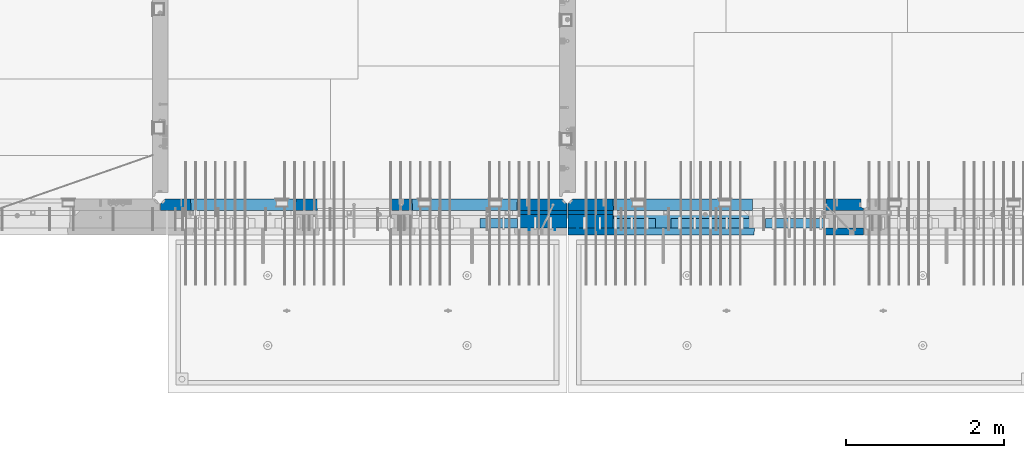
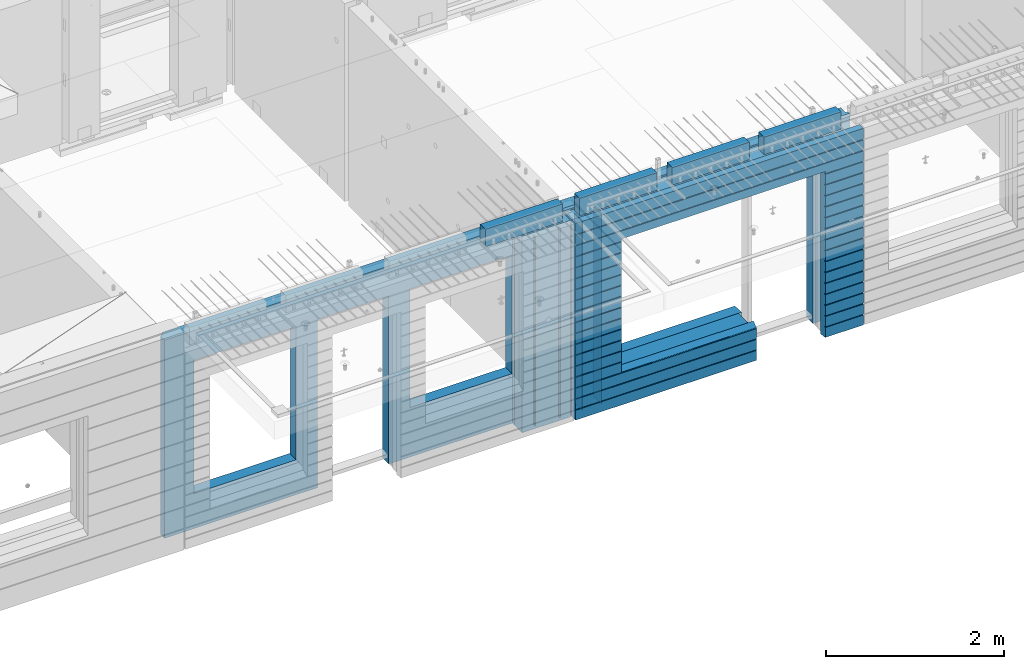
# One storey, part 232 of 352: 16 walls, 8 elements without a shape of their own.
"""IFC2X3 building model written with IfcOpenShell, lengths in millimetres."""

from ifc_helpers import new_model, si_unit, frame, origin_with_axes, place, context, subcontext, project, spatial, faceted_brep, material, type_object, element, aggregate, save


model = new_model("IFC2X3")

# Units and contexts
model_context = context("Model", 3, precision=1e-05, world=origin_with_axes())
body_context = subcontext(model_context, "Body", "Model", "MODEL_VIEW")
ifc_project = project(units=[si_unit("LENGTHUNIT", "METRE", prefix="MILLI"), si_unit("AREAUNIT", "SQUARE_METRE"), si_unit("VOLUMEUNIT", "CUBIC_METRE"), si_unit("MASSUNIT", "GRAM", prefix="KILO"), si_unit("TIMEUNIT", "SECOND"), si_unit("PLANEANGLEUNIT", "RADIAN"), si_unit("SOLIDANGLEUNIT", "STERADIAN"), si_unit("THERMODYNAMICTEMPERATUREUNIT", "DEGREE_CELSIUS"), si_unit("LUMINOUSINTENSITYUNIT", "LUMEN")], contexts=[model_context])

# Site, building, storey
site_placement = place(None, origin_with_axes())
site = spatial("IfcSite", under=ifc_project, at=site_placement, CompositionType="ELEMENT")
building_placement = place(site_placement, origin_with_axes())
building = spatial("IfcBuilding", under=site, at=building_placement, CompositionType="ELEMENT")
storey_placement = place(building_placement, origin_with_axes())
storey = spatial("IfcBuildingStorey", under=building, at=storey_placement, Name="6", CompositionType="ELEMENT", Elevation=0.0)

# Assembly, walls
assembly_1_placement = place(storey_placement, origin_with_axes())
assembly_1 = element("IfcElementAssembly", 1, at=assembly_1_placement, inside=storey, AssemblyPlace="NOTDEFINED", PredefinedType="REINFORCEMENT_UNIT")
ifc_material_1 = material(Name="Undefined")
wall_type_1 = type_object("IfcWallType", PredefinedType="NOTDEFINED")
wall_1_placement = place(assembly_1_placement, frame((21325.0, 7780.0, 98115.0), z_axis=(0.0, 0.0, 1.0), x_axis=(0.0, -1.0, 0.0)))
wall_1 = element("IfcWall", 2, at=wall_1_placement, type_object=wall_type_1, material=ifc_material_1, Name="(PD)", context=body_context, shape_type="Brep", body=[
    faceted_brep([(0.0, 5.0, -1300.0), (0.0, 5.0, 1300.0), (180.0, 5.0, 1300.0), (180.0, 5.0, -1300.0), (0.0, -5.0, 1300.0), (180.0, -5.0, 1300.0), (0.0, -5.0, -1300.0), (180.0, -5.0, -1300.0)], [[[0, 1, 2, 3]], [[1, 4, 5, 2]], [[4, 6, 7, 5]], [[6, 0, 3, 7]], [[5, 7, 3, 2]], [[6, 4, 1, 0]]]),
])
wall_2_placement = place(assembly_1_placement, frame((21650.0, 7780.0, 98115.0), z_axis=(0.0, 0.0, 1.0), x_axis=(0.0, -1.0, 0.0)))
wall_2 = element("IfcWall", 3, at=wall_2_placement, type_object=wall_type_1, material=ifc_material_1, Name="(PD)", context=body_context, shape_type="Brep", body=[
    faceted_brep([(0.0, 5.0, -1300.0), (0.0, 5.0, 1300.0), (180.0, 5.0, 1300.0), (180.0, 5.0, -1300.0), (0.0, -5.0, 1300.0), (180.0, -5.0, 1300.0), (0.0, -5.0, -1300.0), (180.0, -5.0, -1300.0)], [[[0, 1, 2, 3]], [[1, 4, 5, 2]], [[4, 6, 7, 5]], [[6, 0, 3, 7]], [[5, 7, 3, 2]], [[6, 4, 1, 0]]]),
])

assembly_2_placement = place(storey_placement, origin_with_axes())
assembly_2 = element("IfcElementAssembly", 4, at=assembly_2_placement, inside=storey, AssemblyPlace="NOTDEFINED", PredefinedType="REINFORCEMENT_UNIT")
wall_3_placement = place(assembly_2_placement, frame((22190.0, 7780.0, 98115.0), z_axis=(0.0, 0.0, 1.0), x_axis=(0.0, -1.0, 0.0)))
wall_3 = element("IfcWall", 5, at=wall_3_placement, type_object=wall_type_1, material=ifc_material_1, Name="(PD)", context=body_context, shape_type="Brep", body=[
    faceted_brep([(0.0, 5.0, -1300.0), (0.0, 5.0, 1300.0), (180.0, 5.0, 1300.0), (180.0, 5.0, -1300.0), (0.0, -5.0, 1300.0), (180.0, -5.0, 1300.0), (0.0, -5.0, -1300.0), (180.0, -5.0, -1300.0)], [[[0, 1, 2, 3]], [[1, 4, 5, 2]], [[4, 6, 7, 5]], [[6, 0, 3, 7]], [[5, 7, 3, 2]], [[6, 4, 1, 0]]]),
])
wall_4_placement = place(assembly_2_placement, frame((21940.0, 7780.0, 98115.0), z_axis=(0.0, 0.0, 1.0), x_axis=(0.0, -1.0, 0.0)))
wall_4 = element("IfcWall", 6, at=wall_4_placement, type_object=wall_type_1, material=ifc_material_1, Name="(PD)", context=body_context, shape_type="Brep", body=[
    faceted_brep([(0.0, 5.0, -1300.0), (0.0, 5.0, 1300.0), (180.0, 5.0, 1300.0), (180.0, 5.0, -1300.0), (0.0, -5.0, 1300.0), (180.0, -5.0, 1300.0), (0.0, -5.0, -1300.0), (180.0, -5.0, -1300.0)], [[[0, 1, 2, 3]], [[1, 4, 5, 2]], [[4, 6, 7, 5]], [[6, 0, 3, 7]], [[5, 7, 3, 2]], [[6, 4, 1, 0]]]),
])

# Assemblies, wall
assembly_3_placement = place(storey_placement, origin_with_axes())
assembly_3 = element("IfcElementAssembly", 7, at=assembly_3_placement, inside=storey, AssemblyPlace="NOTDEFINED", PredefinedType="REINFORCEMENT_UNIT")
assembly_4_placement = place(assembly_3_placement, origin_with_axes())
assembly_4 = element("IfcElementAssembly", 8, at=assembly_4_placement, Name="Steel Assembly", AssemblyPlace="NOTDEFINED", PredefinedType="NOTDEFINED")
aggregate(assembly_3, [assembly_4])
ifc_material_2 = material()
wall_type_2 = type_object("IfcWallType", PredefinedType="NOTDEFINED")
wall_5_placement = place(assembly_4_placement, frame((20699.9998568133, 7690.00021946163, 99590.0), z_axis=(0.0, 0.0, 1.0), x_axis=(1.0, 0.0, 0.0)))
wall_5 = element("IfcWall", 9, at=wall_5_placement, type_object=wall_type_2, material=ifc_material_2, context=body_context, shape_type="Brep", body=[
    faceted_brep([(0.0, 60.0, -120.0), (0.0, 60.0, 120.0), (1000.0, 60.0, 120.0), (1000.0, 60.0, -120.0), (0.0, -60.0, 120.0), (1000.0, -60.0, 120.0), (0.0, -60.0, -120.0), (1000.0, -60.0, -120.0)], [[[0, 1, 2, 3]], [[1, 4, 5, 2]], [[4, 6, 7, 5]], [[6, 0, 3, 7]], [[5, 7, 3, 2]], [[6, 4, 1, 0]]]),
])
aggregate(assembly_4, [wall_5])

# Assemblies, walls
assembly_5_placement = place(storey_placement, origin_with_axes())
assembly_5 = element("IfcElementAssembly", 10, at=assembly_5_placement, inside=storey, AssemblyPlace="NOTDEFINED", PredefinedType="REINFORCEMENT_UNIT")
assembly_6_placement = place(assembly_5_placement, origin_with_axes())
assembly_6 = element("IfcElementAssembly", 11, at=assembly_6_placement, Name="Steel Assembly", AssemblyPlace="NOTDEFINED", PredefinedType="NOTDEFINED")
wall_6_placement = place(assembly_6_placement, frame((24309.9998568133, 7690.00021946163, 99590.0), z_axis=(0.0, 0.0, 1.0), x_axis=(1.0, 0.0, 0.0)))
wall_6 = element("IfcWall", 12, at=wall_6_placement, type_object=wall_type_2, material=ifc_material_2, context=body_context, shape_type="Brep", body=[
    faceted_brep([(0.0, 60.0, -120.0), (0.0, 60.0, 120.0), (1000.0, 60.0, 120.0), (1000.0, 60.0, -120.0), (0.0, -60.0, 120.0), (1000.0, -60.0, 120.0), (0.0, -60.0, -120.0), (1000.0, -60.0, -120.0)], [[[0, 1, 2, 3]], [[1, 4, 5, 2]], [[4, 6, 7, 5]], [[6, 0, 3, 7]], [[5, 7, 3, 2]], [[6, 4, 1, 0]]]),
])
aggregate(assembly_6, [wall_6])
assembly_7_placement = place(assembly_5_placement, origin_with_axes())
assembly_7 = element("IfcElementAssembly", 13, at=assembly_7_placement, Name="Steel Assembly", AssemblyPlace="NOTDEFINED", PredefinedType="NOTDEFINED")
wall_7_placement = place(assembly_7_placement, frame((23119.9998568133, 7690.00021946163, 99590.0), z_axis=(0.0, 0.0, 1.0), x_axis=(1.0, 0.0, 0.0)))
wall_7 = element("IfcWall", 14, at=wall_7_placement, type_object=wall_type_2, material=ifc_material_2, context=body_context, shape_type="Brep", body=[
    faceted_brep([(0.0, 60.0, -120.0), (0.0, 60.0, 120.0), (1000.0, 60.0, 120.0), (1000.0, 60.0, -120.0), (0.0, -60.0, 120.0), (1000.0, -60.0, 120.0), (0.0, -60.0, -120.0), (1000.0, -60.0, -120.0)], [[[0, 1, 2, 3]], [[1, 4, 5, 2]], [[4, 6, 7, 5]], [[6, 0, 3, 7]], [[5, 7, 3, 2]], [[6, 4, 1, 0]]]),
])
aggregate(assembly_7, [wall_7])
assembly_8_placement = place(assembly_5_placement, origin_with_axes())
assembly_8 = element("IfcElementAssembly", 15, at=assembly_8_placement, Name="Steel Assembly", AssemblyPlace="NOTDEFINED", PredefinedType="NOTDEFINED")
aggregate(assembly_5, [assembly_8, assembly_7, assembly_6])
wall_8_placement = place(assembly_8_placement, frame((21919.9998568133, 7690.00021946163, 99590.0), z_axis=(0.0, 0.0, 1.0), x_axis=(1.0, 0.0, 0.0)))
wall_8 = element("IfcWall", 16, at=wall_8_placement, type_object=wall_type_2, material=ifc_material_2, context=body_context, shape_type="Brep", body=[
    faceted_brep([(0.0, 60.0, -120.0), (0.0, 60.0, 120.0), (1000.0, 60.0, 120.0), (1000.0, 60.0, -120.0), (0.0, -60.0, 120.0), (1000.0, -60.0, 120.0), (0.0, -60.0, -120.0), (1000.0, -60.0, -120.0)], [[[0, 1, 2, 3]], [[1, 4, 5, 2]], [[4, 6, 7, 5]], [[6, 0, 3, 7]], [[5, 7, 3, 2]], [[6, 4, 1, 0]]]),
])
aggregate(assembly_8, [wall_8])

# Wall
ifc_material_3 = material(Name="CONCRETE/C35/45")
wall_type_3 = type_object("IfcWallType", PredefinedType="NOTDEFINED")
wall_9_placement = place(assembly_1_placement, frame((21810.0, 7925.0, 98112.5), z_axis=(0.0, 0.0, 1.0), x_axis=(-1.0, 3.00000001838171e-08, 0.0)))
wall_9 = element("IfcWall", 17, at=wall_9_placement, type_object=wall_type_3, material=ifc_material_3, context=body_context, shape_type="Brep", body=[
    faceted_brep([(5145.0, 75.0, -1357.5), (5145.0, -15.0, -1357.5), (5085.0, -75.0, -1357.5), (3165.00051719707, -75.0, -1357.5), (3161.15436335092, 75.0, -1357.5), (5085.0, -75.0, 1357.5), (5145.0, -15.0, 1357.5), (5145.0, 75.0, 1357.5), (10.0, 75.0, 1357.5), (10.0, -15.0, 1357.5), (70.0, -75.0, 1357.5), (10.0, -15.0, -1357.5), (70.0, -75.0, -1357.5), (10.0, 75.0, -1357.5), (2238.84667104322, 75.0, -1357.5), (2235.00051719707, -75.0, -1357.5), (2238.84667104322, 75.0, 948.653846153844), (2235.00051719707, -75.0, 952.5), (635.00013572734, -75.0, -682.5), (639.054189781393, 75.0, -678.445945945947), (639.054189781393, 75.0, 948.445945945947), (635.00013572734, -75.0, 952.5), (1965.00013572734, -75.0, -682.5), (1960.94608167329, 75.0, -678.445945945947), (1965.00013572734, -75.0, 952.5), (1960.94608167329, 75.0, 948.445945945947), (4764.99937278789, -75.0, -882.5), (4760.94531873383, 75.0, -878.445945945947), (3439.05342684194, 75.0, -878.445945945947), (3434.99937278789, -75.0, -882.5), (3165.00051719707, -75.0, 952.5), (3434.99937278789, -75.0, 952.5), (4764.99937278789, -75.0, 952.5), (4760.94531873383, 75.0, 948.445945945947), (3439.05342684194, 75.0, 948.445945945947), (3161.15436335092, 75.0, 948.653846153844)], [[[0, 1, 2, 3, 4]], [[5, 2, 1, 6]], [[0, 7, 6, 1]], [[5, 6, 7, 8, 9, 10]], [[9, 11, 12, 10]], [[8, 13, 11, 9]], [[12, 11, 13, 14, 15]], [[15, 14, 16, 17]], [[18, 19, 20, 21]], [[22, 23, 19, 18]], [[23, 22, 24, 25]], [[21, 20, 25, 24]], [[26, 27, 28, 29]], [[3, 2, 5, 10, 12, 15, 17, 30], [26, 29, 31, 32], [22, 18, 21, 24]], [[27, 26, 32, 33]], [[31, 34, 33, 32]], [[29, 28, 34, 31]], [[13, 8, 7, 0, 4, 35, 16, 14], [27, 33, 34, 28], [23, 25, 20, 19]], [[17, 16, 35, 30]], [[4, 3, 30, 35]]]),
])

wall_10_placement = place(assembly_2_placement, frame((25550.0, 7925.0, 98112.5), z_axis=(0.0, 0.0, 1.0), x_axis=(-1.0, 3.00000001838171e-08, 0.0)))
wall_10 = element("IfcWall", 18, at=wall_10_placement, type_object=wall_type_3, material=ifc_material_3, context=body_context, shape_type="Brep", body=[
    faceted_brep([(0.0, 75.0, 1357.5), (0.0, 75.0, -1357.5), (0.0, 45.0, -1357.5), (0.0, 45.0, 1357.5), (475.000517197066, -75.0, -1357.5), (478.846671043222, 75.0, -1357.5), (478.846671043219, 75.0, 948.653846153844), (475.000517197066, -75.0, 952.5), (32.5, -75.0, -1357.5), (32.5, 32.0, -1357.5), (32.5, -75.0, 1357.5), (32.5, 32.0, 1357.5), (3675.0, -75.0, 1357.5), (3735.0, -15.0, 1357.5), (3735.0, 75.0, 1357.5), (3735.0, 75.0, -1357.5), (3735.0, -15.0, -1357.5), (3675.0, -75.0, -1357.5), (1405.00051719707, -75.0, -1357.5), (1401.15436335091, 75.0, -1357.5), (1405.00051719707, -75.0, -882.5), (1401.15436335091, 75.0, -878.445945945947), (1334.05403802673, 75.0, 948.653846153844), (3160.9460816706, 75.0, -878.445945945947), (3160.9460816706, 75.0, 948.445945945947), (1401.15436335091, 75.0, 948.653846153844), (1330.00013572465, -75.0, 952.5), (1405.00051719707, -75.0, 952.5), (3165.00013572465, -75.0, -882.5), (3165.00013572465, -75.0, 952.5)], [[[0, 1, 2, 3]], [[4, 5, 6, 7]], [[8, 9, 2, 1, 5, 4]], [[10, 11, 9, 8]], [[3, 2, 9, 11]], [[10, 12, 13, 14, 0, 3, 11]], [[15, 14, 13, 16]], [[12, 17, 16, 13]], [[15, 16, 17, 18, 19]], [[19, 18, 20, 21]], [[22, 6, 5, 1, 0, 14, 15, 19, 21, 23, 24, 25]], [[26, 7, 6, 22, 25, 27]], [[28, 20, 18, 17, 12, 10, 8, 4, 7, 26, 27, 29]], [[25, 24, 29, 27]], [[23, 28, 29, 24]], [[21, 20, 28, 23]]]),
])

wall_type_4 = type_object("IfcWallType", PredefinedType="NOTDEFINED")
wall_11_placement = place(assembly_1_placement, frame((21800.0000381475, 7825.0, 98112.5), z_axis=(0.0, 0.0, 1.0), x_axis=(-1.0, 3.00000001838171e-08, 0.0)))
wall_11 = element("IfcWall", 19, at=wall_11_placement, type_object=wall_type_4, material=ifc_material_3, context=body_context, shape_type="Brep", body=[
    faceted_brep([(0.0, 25.0, -1357.5), (0.0, 25.0, 1357.5), (625.001908754726, 25.0, 1357.5), (625.001908754726, 25.0, -1357.5), (0.0, -25.0, 1357.5), (625.001908754726, -25.0, 1357.5), (0.0, -25.0, -1357.5), (625.001908754726, -25.0, -1357.5)], [[[0, 1, 2, 3]], [[1, 4, 5, 2]], [[4, 6, 7, 5]], [[6, 0, 3, 7]], [[5, 7, 3, 2]], [[6, 4, 1, 0]]]),
])

wall_12_placement = place(assembly_2_placement, frame((22385.0000381475, 7825.00011629906, 98112.5), z_axis=(0.0, 0.0, 1.0), x_axis=(-1.0, 3.00000001838171e-08, 0.0)))
wall_12 = element("IfcWall", 20, at=wall_12_placement, type_object=wall_type_4, material=ifc_material_3, context=body_context, shape_type="Brep", body=[
    faceted_brep([(0.0, 25.0, -1357.5), (0.0, 25.0, 1357.5), (570.001908754726, 25.0, 1357.5), (570.001908754726, 25.0, -1357.5), (0.0, -25.0, 1357.5), (570.001908754726, -25.0, 1357.5), (0.0, -25.0, -1357.5), (570.001908754726, -25.0, -1357.5)], [[[0, 1, 2, 3]], [[1, 4, 5, 2]], [[4, 6, 7, 5]], [[6, 0, 3, 7]], [[5, 7, 3, 2]], [[6, 4, 1, 0]]]),
])

ifc_material_4 = material(Name="SPU")
wall_type_5 = type_object("IfcWallType", PredefinedType="NOTDEFINED")
wall_13_placement = place(assembly_1_placement, frame((21800.0000381475, 7715.0, 98102.5), z_axis=(0.0, 0.0, 1.0), x_axis=(-1.0, 3.00000001838171e-08, 0.0)))
wall_13 = element("IfcWall", 21, at=wall_13_placement, type_object=wall_type_5, material=ifc_material_4, context=body_context, shape_type="Brep", body=[
    faceted_brep([(0.0, 85.0, -1347.5), (0.0, 85.0, 1347.5), (625.001908754726, 85.0, 1347.5), (625.001908754726, 85.0, -1347.5), (0.0, -85.0, 1347.5), (625.001908754726, -85.0, 1347.5), (0.0, -85.0, -1347.5), (625.001908754726, -85.0, -1347.5)], [[[0, 1, 2, 3]], [[1, 4, 5, 2]], [[4, 6, 7, 5]], [[6, 0, 3, 7]], [[5, 7, 3, 2]], [[6, 4, 1, 0]]]),
])

aggregate(assembly_1, [wall_13, wall_11, wall_1, wall_2, wall_9])

wall_14_placement = place(assembly_2_placement, frame((22385.0000381475, 7715.00011629906, 98102.5), z_axis=(0.0, 0.0, 1.0), x_axis=(-1.0, 3.00000001838171e-08, 0.0)))
wall_14 = element("IfcWall", 22, at=wall_14_placement, type_object=wall_type_5, material=ifc_material_4, context=body_context, shape_type="Brep", body=[
    faceted_brep([(0.0, 85.0, -1347.5), (0.0, 85.0, 1347.5), (570.001908754726, 85.0, 1347.5), (570.001908754726, 85.0, -1347.5), (0.0, -85.0, 1347.5), (570.001908754726, -85.0, 1347.5), (0.0, -85.0, -1347.5), (570.001908754726, -85.0, -1347.5)], [[[0, 1, 2, 3]], [[1, 4, 5, 2]], [[4, 6, 7, 5]], [[6, 0, 3, 7]], [[5, 7, 3, 2]], [[6, 4, 1, 0]]]),
])

ifc_material_5 = material(Name="CONCRETE/C30/37")
wall_type_6 = type_object("IfcWallType", PredefinedType="NOTDEFINED")
wall_15_placement = place(assembly_2_placement, frame((25550.0, 7587.5, 98102.5), z_axis=(0.0, 0.0, 1.0), x_axis=(-1.0, 3.00000001838171e-08, 0.0)))
wall_15 = element("IfcWall", 23, at=wall_15_placement, type_object=wall_type_6, material=ifc_material_5, context=body_context, shape_type="Brep", body=[
    faceted_brep([(3135.00013572465, 42.5, -912.000000055254), (3135.00013572465, 42.5, -912.5), (3134.8486205936, 41.2121213860491, -911.742424344731), (3735.0, 32.4999991126861, -1049.99999959956), (3735.0, 32.4999992506973, -1060.00000000076), (1383.82179161871, 32.4999992506973, -1060.00000000076), (1383.82179160247, 32.4999991126861, -1049.99999959956), (3735.0, 42.5, -1062.00000005522), (1384.99845837354, 42.5, -1062.00000005522), (3735.0, 42.5, -1198.00000011075), (1384.99845837354, 42.5, -1198.00000011075), (3735.0, 32.4999991121604, -1199.99999959957), (1383.8217916024, 32.4999991121604, -1199.99999959957), (3735.0, 32.4999992501671, -1210.00000000079), (1383.82179161864, 32.4999992501671, -1210.00000000079), (3735.0, 42.5, -1212.00000005524), (1384.99845837354, 42.5, -1212.00000005524), (3735.0, 42.5, -1347.5), (1384.99845837354, 42.5, -1347.5), (3735.0, -42.5, -1347.5), (1374.99679170687, -42.5, -1347.5), (3.63797880709171e-12, 32.4999992499725, 1039.99999999921), (3735.0, 32.4999992499725, 1039.99999999921), (3735.0, 42.5, 1037.99999994476), (0.0, 42.5, 1037.99999994476), (3.63797880709171e-12, 32.4999991119639, 1050.00000040043), (3735.0, 32.4999991119639, 1050.00000040043), (0.0, 42.5, 1051.99999988925), (3735.0, 42.5, 1051.99999988925), (0.0, 42.5, 1187.99999994476), (3735.0, 42.5, 1187.99999994476), (-3.63797880709171e-12, 32.499999249967, 1189.99999999923), (3735.0, 32.499999249967, 1189.99999999923), (-3.63797880709171e-12, 32.4999991119576, 1200.00000040043), (3735.0, 32.4999991119576, 1200.00000040043), (0.0, 42.5, 1201.99999988925), (3735.0, 42.5, 1201.99999988925), (0.0, 42.5, 1347.5), (3735.0, 42.5, 1347.5), (0.0, -42.5, 1347.5), (3735.0, -42.5, 1347.5), (3125.00013572465, -42.5, 927.5), (3125.00013572465, -42.5, -862.5), (1374.99679170687, -42.5, -862.5), (0.0, -42.5, -1347.5), (505.000125040202, -42.5, -1347.5), (505.000125040206, -42.5, 927.5), (505.000125040206, -42.5, 932.502857142856), (1370.00013572465, -42.5, 932.502857142856), (1374.99679170687, -42.5, 932.5), (3125.00013572465, -42.5, 932.5), (0.0, 42.5, -1347.5), (494.998458373539, 42.5, -1347.5), (0.0, 42.5, -1212.00000005524), (494.998458373539, 42.5, -1212.00000005524), (0.0, 32.4999992501671, -1210.00000000079), (496.175125128437, 32.4999992501671, -1210.00000000079), (0.0, 32.4999991121604, -1199.99999959957), (496.175125144673, 32.4999991121604, -1199.99999959957), (0.0, 42.5, -1198.00000011075), (494.998458373539, 42.5, -1198.00000011075), (0.0, 42.5, -1062.00000005522), (494.998458373539, 42.5, -1062.00000005522), (0.0, 32.4999992506973, -1060.00000000076), (496.175125128375, 32.4999992506973, -1060.00000000076), (0.0, 32.4999991126861, -1049.99999959956), (496.175125144611, 32.4999991126861, -1049.99999959956), (0.0, 42.5, -1048.00000011074), (494.998458373539, 42.5, -1048.00000011074), (0.0, 42.5, -912.000000055254), (494.998458373539, 42.5, -912.000000055254), (0.0, 32.4999992512376, -910.000000000786), (496.175125128309, 32.4999992512376, -910.000000000786), (0.0, 32.499999113239, -899.99999959959), (496.175125144546, 32.499999113239, -899.99999959959), (0.0, 42.5, -898.000000110769), (494.998458373539, 42.5, -898.000000110769), (0.0, 42.5, -762.000000055225), (494.998458373539, 42.5, -762.000000055225), (0.0, 32.4999992517696, -760.000000000757), (496.175125128244, 32.4999992517696, -760.000000000757), (0.0, 32.4999991137702, -749.99999959956), (496.175125144484, 32.4999991137702, -749.99999959956), (0.0, 42.5, -748.00000011074), (494.998458373539, 42.5, -748.00000011074), (0.0, 42.5, -612.000000055239), (494.998458373539, 42.5, -612.000000055239), (0.0, 32.4999992522971, -610.000000000771), (496.175125128182, 32.4999992522971, -610.000000000771), (0.0, 32.4999991143004, -599.99999959956), (496.175125144422, 32.4999991143004, -599.99999959956), (0.0, 42.5, -598.000000110755), (494.998458373539, 42.5, -598.000000110755), (0.0, 42.5, -462.000000055239), (494.998458373539, 42.5, -462.000000055239), (0.0, 32.4999992528365, -460.000000000771), (496.17512512812, 32.4999992528365, -460.000000000771), (0.0, 32.4999991148252, -449.999999599575), (496.17512514436, 32.4999991148252, -449.999999599575), (0.0, 42.5, -448.000000110755), (494.998458373539, 42.5, -448.000000110755), (0.0, 42.5, -312.000000055254), (494.998458373539, 42.5, -312.000000055254), (0.0, 32.4999992533649, -310.000000000786), (496.175125128058, 32.4999992533649, -310.000000000786), (0.0, 32.4999991153618, -299.99999959959), (496.175125144298, 32.4999991153618, -299.99999959959), (0.0, 42.5, -298.000000110769), (494.998458373539, 42.5, -298.000000110769), (0.0, 42.5, -162.000000055239), (494.998458373539, 42.5, -162.000000055239), (0.0, 32.4999992538978, -160.000000000757), (496.175125127997, 32.4999992538978, -160.000000000757), (0.0, 32.4999991158993, -149.99999959956), (496.175125144237, 32.4999991158993, -149.99999959956), (0.0, 42.5, -148.000000110755), (494.998458373539, 42.5, -148.000000110755), (0.0, 42.5, -12.0000000552391), (494.998458373539, 42.5, -12.0000000552391), (0.0, 32.4999992538942, -10.0000000007858), (496.175125127997, 32.4999992538942, -10.0000000007858), (3.63797880709171e-12, 32.4999992499852, 889.999999999229), (3.63797880709171e-12, 32.4999991119857, 900.000000400425), (496.175125144691, 32.4999991119857, 900.000000400425), (496.175125128459, 32.4999992499852, 889.999999999229), (0.0, 42.5, 887.999999944761), (494.998458373539, 42.5, 887.999999944761), (0.0, 42.5, 751.999999889245), (494.998458373539, 42.5, 751.999999889245), (0.0, 32.4999991120039, 750.00000040044), (496.175125144691, 32.4999991120039, 750.00000040044), (0.0, 32.4999992499997, 739.999999999229), (496.175125128455, 32.4999992499997, 739.999999999229), (0.0, 42.5, 737.999999944761), (494.998458373539, 42.5, 737.999999944761), (0.0, 42.5, 601.99999988926), (494.998458373539, 42.5, 601.99999988926), (0.0, 32.4999991120094, 600.00000040044), (496.175125144691, 32.4999991120094, 600.00000040044), (0.0, 32.499999250017, 589.999999999229), (496.175125128455, 32.499999250017, 589.999999999229), (0.0, 42.5, 587.999999944775), (494.998458373539, 42.5, 587.999999944775), (0.0, 42.5, 451.999999889231), (494.998458373539, 42.5, 451.999999889231), (0.0, 32.4999991120258, 450.000000400411), (496.175125144688, 32.4999991120258, 450.000000400411), (0.0, 32.4999992500289, 439.999999999214), (496.175125128451, 32.4999992500289, 439.999999999214), (0.0, 42.5, 437.999999944746), (494.998458373539, 42.5, 437.999999944746), (0.0, 42.5, 301.999999889245), (494.998458373539, 42.5, 301.999999889245), (-3.63797880709171e-12, 32.4999991120458, 300.00000040044), (496.175125144688, 32.4999991120458, 300.00000040044), (-3.63797880709171e-12, 32.4999992500416, 289.999999999229), (496.175125128451, 32.4999992500416, 289.999999999229), (0.0, 42.5, 287.999999944761), (494.998458373539, 42.5, 287.999999944761), (0.0, 42.5, 151.99999988926), (494.998458373539, 42.5, 151.99999988926), (0.0, 32.4999991120549, 150.00000040044), (496.175125144684, 32.4999991120549, 150.00000040044), (0.0, 32.4999992500552, 139.999999999229), (496.175125128448, 32.4999992500552, 139.999999999229), (0.0, 42.5, 137.999999944775), (494.998458373539, 42.5, 137.999999944775), (0.0, 42.5, 1.99999988924537), (494.998458373539, 42.5, 1.99999988924537), (0.0, 32.4999991158911, 4.00425051338971e-07), (496.175125144237, 32.4999991158911, 4.00425051338971e-07), (0.0, 42.5, 901.999999889245), (494.998458373539, 42.5, 901.999999889245), (494.998458373539, 42.5, 927.5), (505.000517197066, 42.5, 927.5), (1360.00013572465, 42.5, 927.5), (1370.00013572465, 42.5, 927.5), (1375.00051719707, 42.5, 927.5), (1384.99845837354, 42.5, 927.5), (3125.00013572465, 42.5, 927.5), (3135.00013572465, 42.5, 927.5), (3735.0, 42.5, 901.999999889245), (3135.00013572465, 42.5, 901.999999889245), (3735.0, 32.4999991119857, 900.000000400425), (3133.82366503195, 32.4999991119857, 900.000000400425), (3735.0, 32.4999992499852, 889.999999999229), (3133.82366504818, 32.4999992499852, 889.999999999229), (3735.0, 42.5, 887.999999944761), (3135.00013572465, 42.5, 887.999999944761), (3735.0, 42.5, 751.999999889245), (3135.00013572465, 42.5, 751.999999889245), (3735.0, 32.4999991120039, 750.00000040044), (3133.82366503195, 32.4999991120039, 750.00000040044), (3735.0, 32.4999992499997, 739.999999999229), (3133.82366504818, 32.4999992499997, 739.999999999229), (3735.0, 42.5, 737.999999944761), (3135.00013572465, 42.5, 737.999999944761), (3735.0, 42.5, 601.99999988926), (3135.00013572465, 42.5, 601.99999988926), (3735.0, 32.4999991120094, 600.00000040044), (3133.82366503195, 32.4999991120094, 600.00000040044), (3735.0, 32.499999250017, 589.999999999229), (3133.82366504818, 32.499999250017, 589.999999999229), (3735.0, 42.5, 587.999999944775), (3135.00013572465, 42.5, 587.999999944775), (3735.0, 42.5, 451.999999889231), (3135.00013572465, 42.5, 451.999999889231), (3735.0, 32.4999991120258, 450.000000400411), (3133.82366503195, 32.4999991120258, 450.000000400411), (3735.0, 32.4999992500289, 439.999999999214), (3133.82366504818, 32.4999992500289, 439.999999999214), (3735.0, 42.5, 437.999999944746), (3135.00013572465, 42.5, 437.999999944746), (3735.0, 42.5, 301.999999889245), (3135.00013572465, 42.5, 301.999999889245), (3735.0, 32.4999991120458, 300.00000040044), (3133.82366503195, 32.4999991120458, 300.00000040044), (3735.0, 32.4999992500416, 289.999999999229), (3133.82366504819, 32.4999992500416, 289.999999999229), (3735.0, 42.5, 287.999999944761), (3135.00013572465, 42.5, 287.999999944761), (3735.0, 42.5, 151.99999988926), (3135.00013572465, 42.5, 151.99999988926), (3735.0, 32.4999991120549, 150.00000040044), (3133.82366503195, 32.4999991120549, 150.00000040044), (3735.0, 32.4999992500552, 139.999999999229), (3133.82366504819, 32.4999992500552, 139.999999999229), (3735.0, 42.5, 137.999999944775), (3135.00013572465, 42.5, 137.999999944775), (3735.0, 42.5, 1.99999988924537), (3135.00013572465, 42.5, 1.99999988924537), (3735.0, 32.4999991158911, 4.00425051338971e-07), (3735.0, 32.4999992538942, -10.0000000007858), (3133.82366504864, 32.4999992538942, -10.0000000007858), (3133.8236650324, 32.4999991158911, 4.00425051338971e-07), (3735.0, 42.5, -12.0000000552391), (3135.00013572465, 42.5, -12.0000000552391), (3735.0, 42.5, -148.000000110755), (3135.00013572465, 42.5, -148.000000110755), (3735.0, 32.4999991158993, -149.99999959956), (3133.8236650324, 32.4999991158993, -149.99999959956), (3735.0, 32.4999992538978, -160.000000000757), (3133.82366504864, 32.4999992538978, -160.000000000757), (3735.0, 42.5, -162.000000055239), (3135.00013572465, 42.5, -162.000000055239), (3735.0, 42.5, -298.000000110769), (3135.00013572465, 42.5, -298.000000110769), (3735.0, 32.4999991153618, -299.99999959959), (3133.82366503234, 32.4999991153618, -299.99999959959), (3735.0, 32.4999992533649, -310.000000000786), (3133.82366504858, 32.4999992533649, -310.000000000786), (3735.0, 42.5, -312.000000055254), (3135.00013572465, 42.5, -312.000000055254), (3735.0, 42.5, -448.000000110755), (3135.00013572465, 42.5, -448.000000110755), (3735.0, 32.4999991148252, -449.999999599575), (3133.82366503228, 32.4999991148252, -449.999999599575), (3735.0, 32.4999992528365, -460.000000000771), (3133.82366504852, 32.4999992528365, -460.000000000771), (3735.0, 42.5, -462.000000055239), (3135.00013572465, 42.5, -462.000000055239), (3735.0, 42.5, -598.000000110755), (3135.00013572465, 42.5, -598.000000110755), (3735.0, 32.4999991143004, -599.99999959956), (3133.82366503222, 32.4999991143004, -599.99999959956), (3735.0, 32.4999992522971, -610.000000000771), (3133.82366504845, 32.4999992522971, -610.000000000771), (3735.0, 42.5, -612.000000055239), (3135.00013572465, 42.5, -612.000000055239), (3735.0, 42.5, -748.00000011074), (3135.00013572465, 42.5, -748.00000011074), (3735.0, 32.4999991137702, -749.99999959956), (3133.82366503216, 32.4999991137702, -749.99999959956), (3735.0, 32.4999992517696, -760.000000000757), (3133.82366504839, 32.4999992517696, -760.000000000757), (3735.0, 42.5, -762.000000055225), (3135.00013572465, 42.5, -762.000000055225), (3735.0, 42.5, -898.000000110769), (3135.00013572465, 42.5, -898.000000110769), (3735.0, 32.499999113239, -899.99999959959), (3133.82366503209, 32.499999113239, -899.99999959959), (3133.82366504284, 32.4999992045623, -906.617646590923), (3735.0, 42.5, -1048.00000011074), (3735.0, 42.5, -912.000000055254), (3735.0, 32.4999992512376, -910.000000000786), (1384.99845837354, 42.5, -1048.00000011074), (1384.99845837354, 42.5, -912.5), (1384.84691798997, 41.2121213860719, -911.742424344746), (1383.82179161877, 32.4999992512376, -910.000000000786), (1383.82179161327, 32.4999992045614, -906.617646590908)], [[[0, 1, 2]], [[3, 4, 5, 6]], [[4, 7, 8, 5]], [[7, 9, 10, 8]], [[9, 11, 12, 10]], [[11, 13, 14, 12]], [[13, 15, 16, 14]], [[15, 17, 18, 16]], [[17, 19, 20, 18]], [[21, 22, 23, 24]], [[25, 26, 22, 21]], [[27, 28, 26, 25]], [[28, 27, 29, 30]], [[31, 32, 30, 29]], [[33, 34, 32, 31]], [[35, 36, 34, 33]], [[37, 38, 36, 35]], [[37, 39, 40, 38]], [[41, 42, 43, 20, 19, 40, 39, 44, 45, 46, 47, 48, 49, 50]], [[44, 51, 52, 45]], [[51, 53, 54, 52]], [[53, 55, 56, 54]], [[55, 57, 58, 56]], [[57, 59, 60, 58]], [[59, 61, 62, 60]], [[61, 63, 64, 62]], [[63, 65, 66, 64]], [[65, 67, 68, 66]], [[67, 69, 70, 68]], [[69, 71, 72, 70]], [[71, 73, 74, 72]], [[73, 75, 76, 74]], [[75, 77, 78, 76]], [[77, 79, 80, 78]], [[79, 81, 82, 80]], [[81, 83, 84, 82]], [[83, 85, 86, 84]], [[85, 87, 88, 86]], [[87, 89, 90, 88]], [[89, 91, 92, 90]], [[91, 93, 94, 92]], [[93, 95, 96, 94]], [[95, 97, 98, 96]], [[97, 99, 100, 98]], [[99, 101, 102, 100]], [[101, 103, 104, 102]], [[103, 105, 106, 104]], [[105, 107, 108, 106]], [[107, 109, 110, 108]], [[109, 111, 112, 110]], [[111, 113, 114, 112]], [[113, 115, 116, 114]], [[115, 117, 118, 116]], [[117, 119, 120, 118]], [[121, 122, 123, 124]], [[125, 121, 124, 126]], [[127, 125, 126, 128]], [[129, 127, 128, 130]], [[131, 129, 130, 132]], [[133, 131, 132, 134]], [[135, 133, 134, 136]], [[137, 135, 136, 138]], [[139, 137, 138, 140]], [[141, 139, 140, 142]], [[143, 141, 142, 144]], [[145, 143, 144, 146]], [[147, 145, 146, 148]], [[149, 147, 148, 150]], [[151, 149, 150, 152]], [[153, 151, 152, 154]], [[155, 153, 154, 156]], [[157, 155, 156, 158]], [[159, 157, 158, 160]], [[161, 159, 160, 162]], [[163, 161, 162, 164]], [[165, 163, 164, 166]], [[167, 165, 166, 168]], [[169, 167, 168, 170]], [[119, 169, 170, 120]], [[117, 115, 113, 111, 109, 107, 105, 103, 101, 99, 97, 95, 93, 91, 89, 87, 85, 83, 81, 79, 77, 75, 73, 71, 69, 67, 65, 63, 61, 59, 57, 55, 53, 51, 44, 39, 37, 35, 33, 31, 29, 27, 25, 21, 24, 171, 122, 121, 125, 127, 129, 131, 133, 135, 137, 139, 141, 143, 145, 147, 149, 151, 153, 155, 157, 159, 161, 163, 165, 167, 169, 119]], [[122, 171, 172, 123]], [[173, 47, 46, 45, 52, 54, 56, 58, 60, 62, 64, 66, 68, 70, 72, 74, 76, 78, 80, 82, 84, 86, 88, 90, 92, 94, 96, 98, 100, 102, 104, 106, 108, 110, 112, 114, 116, 118, 120, 170, 168, 166, 164, 162, 160, 158, 156, 154, 152, 150, 148, 146, 144, 142, 140, 138, 136, 134, 132, 130, 128, 126, 124, 123, 172]], [[174, 175, 176, 177, 178, 49, 48, 47, 173]], [[49, 178, 179, 180, 50]], [[178, 177, 176, 175, 174, 173, 172, 171, 24, 23, 181, 182, 180, 179]], [[181, 183, 184, 182]], [[183, 185, 186, 184]], [[185, 187, 188, 186]], [[187, 189, 190, 188]], [[189, 191, 192, 190]], [[191, 193, 194, 192]], [[193, 195, 196, 194]], [[195, 197, 198, 196]], [[197, 199, 200, 198]], [[199, 201, 202, 200]], [[201, 203, 204, 202]], [[203, 205, 206, 204]], [[205, 207, 208, 206]], [[207, 209, 210, 208]], [[209, 211, 212, 210]], [[211, 213, 214, 212]], [[213, 215, 216, 214]], [[215, 217, 218, 216]], [[217, 219, 220, 218]], [[219, 221, 222, 220]], [[221, 223, 224, 222]], [[223, 225, 226, 224]], [[225, 227, 228, 226]], [[227, 229, 230, 228]], [[231, 232, 233, 234]], [[232, 235, 236, 233]], [[235, 237, 238, 236]], [[237, 239, 240, 238]], [[239, 241, 242, 240]], [[241, 243, 244, 242]], [[243, 245, 246, 244]], [[245, 247, 248, 246]], [[247, 249, 250, 248]], [[249, 251, 252, 250]], [[251, 253, 254, 252]], [[253, 255, 256, 254]], [[255, 257, 258, 256]], [[257, 259, 260, 258]], [[259, 261, 262, 260]], [[261, 263, 264, 262]], [[263, 265, 266, 264]], [[265, 267, 268, 266]], [[267, 269, 270, 268]], [[269, 271, 272, 270]], [[271, 273, 274, 272]], [[273, 275, 276, 274]], [[275, 277, 278, 276]], [[277, 279, 280, 278]], [[41, 50, 180, 182, 184, 186, 188, 190, 192, 194, 196, 198, 200, 202, 204, 206, 208, 210, 212, 214, 216, 218, 220, 222, 224, 226, 228, 230, 234, 233, 236, 238, 240, 242, 244, 246, 248, 250, 252, 254, 256, 258, 260, 262, 264, 266, 268, 270, 272, 274, 276, 278, 280, 281, 42]], [[229, 231, 234, 230]], [[227, 225, 223, 221, 219, 217, 215, 213, 211, 209, 207, 205, 203, 201, 199, 197, 195, 193, 191, 189, 187, 185, 183, 181, 23, 22, 26, 28, 30, 32, 34, 36, 38, 40, 19, 17, 15, 13, 11, 9, 7, 4, 3, 282, 283, 284, 279, 277, 275, 273, 271, 269, 267, 265, 263, 261, 259, 257, 255, 253, 251, 249, 247, 245, 243, 241, 239, 237, 235, 232, 231, 229]], [[0, 283, 282, 285, 286, 1]], [[287, 2, 1, 286]], [[288, 284, 283, 0, 2, 287]], [[280, 279, 284, 288, 289, 281]], [[43, 42, 281, 289]], [[288, 287, 286, 285, 6, 5, 8, 10, 12, 14, 16, 18, 20, 43, 289]], [[282, 3, 6, 285]]]),
])

ifc_material_6 = material(Name="COS5gt")
wall_type_7 = type_object("IfcWallType", PredefinedType="NOTDEFINED")
wall_16_placement = place(assembly_2_placement, frame((25075.0, 7740.0, 98102.5), z_axis=(0.0, 0.0, 1.0), x_axis=(-1.0, 3.00000001838171e-08, 0.0)))
wall_16 = element("IfcWall", 24, at=wall_16_placement, type_object=wall_type_7, material=ifc_material_6, context=body_context, shape_type="Brep", body=[
    faceted_brep([(2690.0, 90.0, -1297.5), (2690.0, 90.0, -1347.5), (970.000517197066, 90.0, -1347.5), (970.000517197066, 90.0, -1297.5), (2690.0, 110.0, -1297.5), (970.000517197066, 110.0, -1297.5), (2690.0, 110.0, 1347.5), (2690.0, -110.0, 1347.5), (2690.0, -110.0, -1347.5), (0.0, 110.0, 1347.5), (0.0, -110.0, 1347.5), (0.0, 110.0, 1002.5), (0.0, -110.0, 1002.5), (970.000517197066, 110.0, 1002.5), (970.000517197066, -110.0, 1002.5), (970.000517197066, 110.0, 952.5), (970.000517197066, -110.0, 958.445945945947), (2685.9460816706, -110.000000000001, -868.445945945947), (970.000517197066, -110.0, -868.445945945947), (970.000517197066, -110.0, -1347.5), (2685.9460816706, -110.0, 958.445945945947), (2680.00013572465, 110.0, -857.5), (2680.00013572465, 110.0, -862.5), (2680.00013572465, 110.0, 952.5), (970.000517197066, 110.0, -862.5), (2650.00013572465, 110.0, -862.5)], [[[0, 1, 2, 3]], [[4, 0, 3, 5]], [[6, 7, 8, 1, 0, 4]], [[9, 10, 7, 6]], [[10, 9, 11, 12]], [[12, 11, 13, 14]], [[14, 13, 15, 16]], [[17, 18, 19, 8, 7, 10, 12, 14, 16, 20]], [[21, 22, 17, 20, 23]], [[16, 15, 23, 20]], [[13, 11, 9, 6, 4, 5, 24, 25, 22, 21, 23, 15]], [[18, 17, 22, 25, 24]], [[5, 3, 2, 19, 18, 24]], [[1, 8, 19, 2]]]),
])

aggregate(assembly_2, [wall_14, wall_12, wall_3, wall_4, wall_15, wall_16, wall_10])

save(model, "model.ifc")
